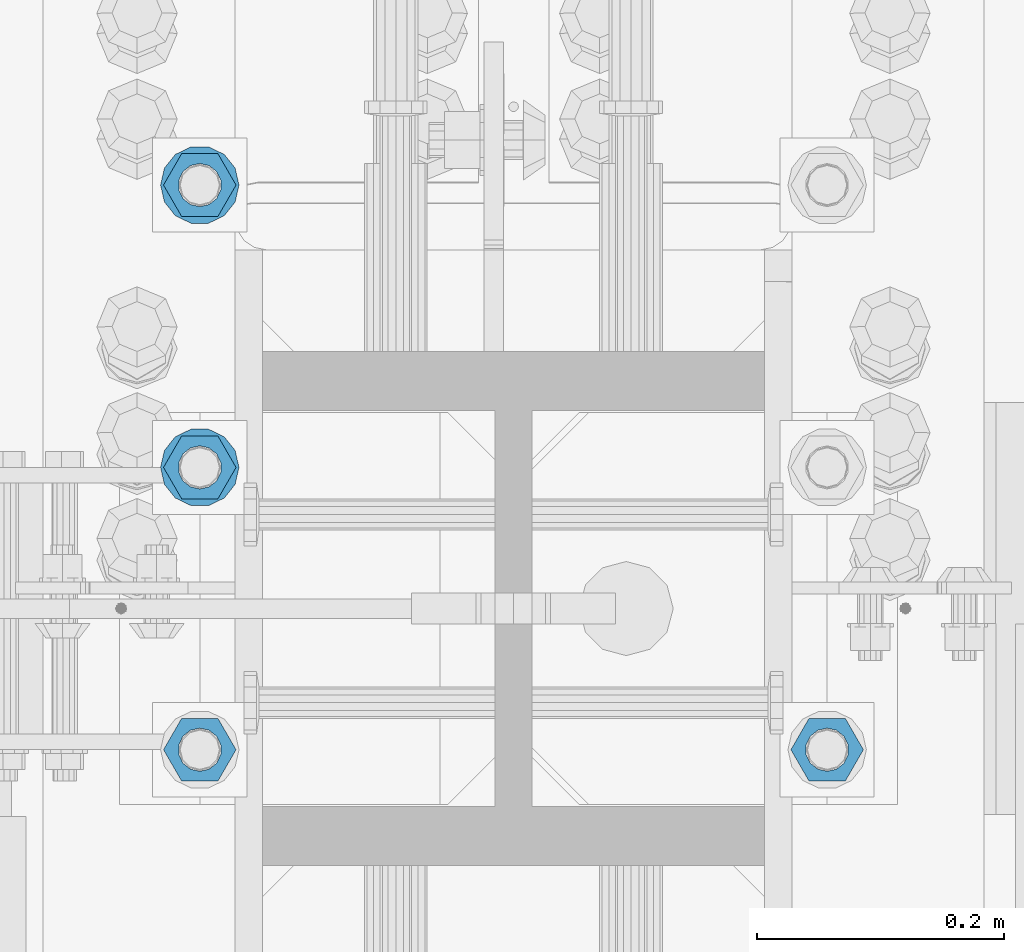
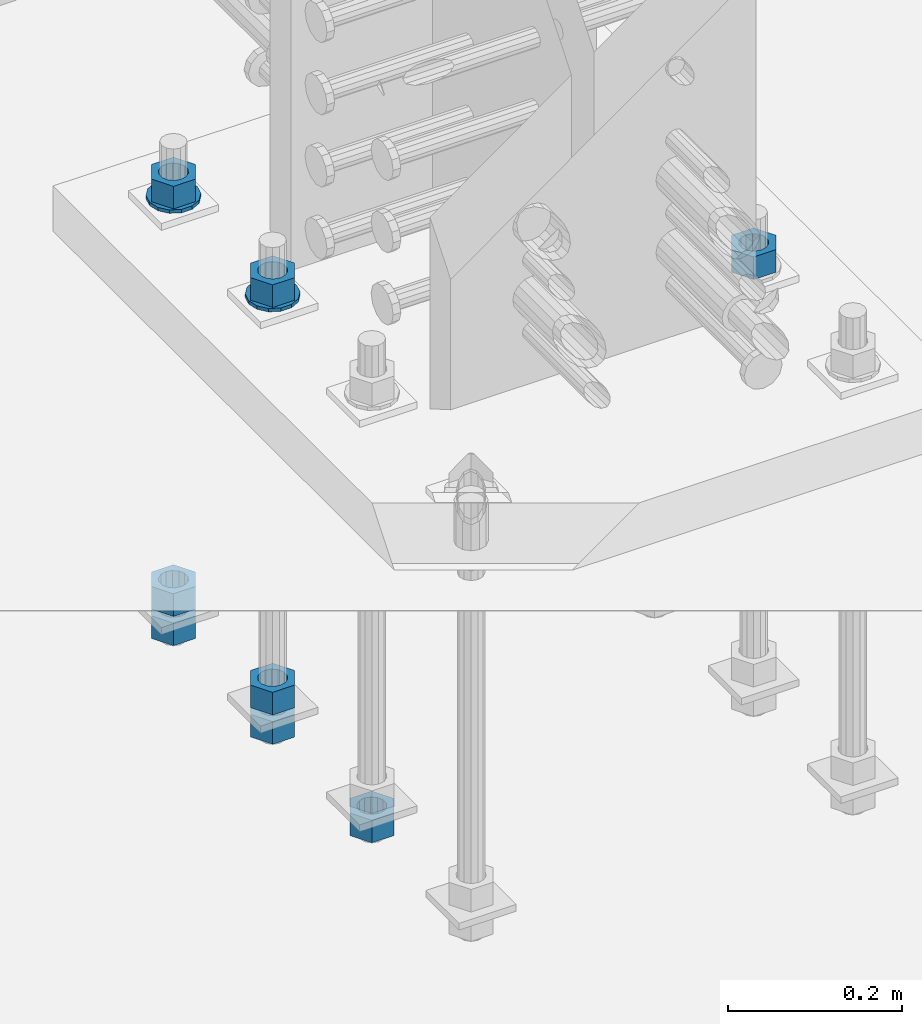
# One storey, part 1008 of 1763: 10 columns, 1 element without a shape of its own.
"""IFC2X3 building model written with IfcOpenShell, lengths in millimetres."""

from ifc_helpers import new_model, si_unit, frame, origin_with_axes, place, context, subcontext, project, spatial, faceted_brep, material, type_object, element, aggregate, save


model = new_model("IFC2X3")

# Units and contexts
model_context = context("Model", 3, precision=1e-05, world=origin_with_axes())
body_context = subcontext(model_context, "Body", "Model", "MODEL_VIEW")
ifc_project = project(units=[si_unit("LENGTHUNIT", "METRE", prefix="MILLI"), si_unit("AREAUNIT", "SQUARE_METRE"), si_unit("VOLUMEUNIT", "CUBIC_METRE"), si_unit("MASSUNIT", "GRAM", prefix="KILO"), si_unit("TIMEUNIT", "SECOND"), si_unit("PLANEANGLEUNIT", "RADIAN"), si_unit("SOLIDANGLEUNIT", "STERADIAN"), si_unit("THERMODYNAMICTEMPERATUREUNIT", "DEGREE_CELSIUS"), si_unit("LUMINOUSINTENSITYUNIT", "LUMEN")], contexts=[model_context])

# Site, building, storey
site_placement = place(None, origin_with_axes())
site = spatial("IfcSite", under=ifc_project, at=site_placement, CompositionType="ELEMENT")
building_placement = place(site_placement, origin_with_axes())
building = spatial("IfcBuilding", under=site, at=building_placement, Name="Undefined", CompositionType="ELEMENT")
storey_placement = place(building_placement, origin_with_axes())
storey = spatial("IfcBuildingStorey", under=building, at=storey_placement, Name="Undefined", CompositionType="ELEMENT", Elevation=0.0)

# Assembly, columns
assembly_placement = place(storey_placement, origin_with_axes())
assembly = element("IfcElementAssembly", 1, at=assembly_placement, inside=storey, Name="TEMPLATE", AssemblyPlace="NOTDEFINED", PredefinedType="RIGID_FRAME")
ifc_material_1 = material(Name="STEEL/A563")
column_type_1 = type_object("IfcColumnType", Name="1-1/4_HEAVY_HEX_NUT", PredefinedType="NOTDEFINED")
column_1_placement = place(assembly_placement, frame((-24281.8372736984, -13830.3000000001, 3343.275), z_axis=(0.0, -1.0, 0.0), x_axis=(0.0, 0.0, -1.0)))
column_1 = element("IfcColumn", 2, at=column_1_placement, type_object=column_type_1, material=ifc_material_1, Name="NUT", ObjectType="1-1/4_HEAVY_HEX_NUT", context=body_context, shape_type="Brep", body=[
    faceted_brep([(0.0, -29.3700008392334, 0.0), (0.0, -14.6800003051758, -25.4300003051758), (31.75, -14.6800003051758, -25.4300003051758), (31.75, -29.3700008392334, 0.0), (0.0, 14.6800003051758, -25.4300003051758), (31.75, 14.6800003051758, -25.4300003051758), (0.0, 29.3700008392334, 0.0), (31.75, 29.3700008392334, 0.0), (0.0, 14.6800003051758, 25.4300003051758), (31.75, 14.6800003051758, 25.4300003051758), (0.0, -14.6800003051758, 25.4300003051758), (31.75, -14.6800003051758, 25.4300003051758), (0.0, 0.0, 17.4599990844727), (0.0, 7.57560968776022, 15.730915608714), (31.75, 7.57560968775942, 15.7309156087145), (31.75, 0.0, 17.4599990844727), (0.0, 13.6507769681037, 10.8861313696252), (31.75, 13.6507769681048, 10.8861313696314), (0.0, 17.0222404541215, 3.88521530314756), (31.75, 17.02224045412, 3.88521530315316), (0.0, 17.0222404541215, -3.88521530314756), (31.75, 17.02224045412, -3.88521530315332), (0.0, 13.6507769681037, -10.8861313696252), (31.75, 13.6507769681048, -10.8861313696316), (0.0, 7.57560968776022, -15.730915608714), (31.75, 7.57560968775942, -15.7309156087146), (0.0, 0.0, -17.4599990844727), (31.75, 0.0, -17.4599990844727), (0.0, -7.57560968776022, -15.730915608714), (31.75, -7.57560968775942, -15.7309156087145), (0.0, -13.6507769681037, -10.8861313696252), (31.75, -13.6507769681048, -10.8861313696314), (0.0, -17.0222404541215, -3.88521530314756), (31.75, -17.02224045412, -3.88521530315316), (0.0, -17.0222404541215, 3.88521530314756), (31.75, -17.02224045412, 3.88521530315332), (0.0, -13.6507769681037, 10.8861313696252), (31.75, -13.6507769681048, 10.8861313696316), (0.0, -7.57560968776022, 15.730915608714), (31.75, -7.57560968775942, 15.7309156087146)], [[[0, 1, 2, 3]], [[1, 4, 5, 2]], [[4, 6, 7, 5]], [[6, 8, 9, 7]], [[8, 10, 11, 9]], [[10, 0, 3, 11]], [[12, 13, 14, 15]], [[13, 16, 17, 14]], [[16, 18, 19, 17]], [[18, 20, 21, 19]], [[20, 22, 23, 21]], [[22, 24, 25, 23]], [[24, 26, 27, 25]], [[26, 28, 29, 27]], [[28, 30, 31, 29]], [[30, 32, 33, 31]], [[32, 34, 35, 33]], [[34, 36, 37, 35]], [[36, 38, 39, 37]], [[38, 12, 15, 39]], [[5, 7, 9, 11, 3, 2], [17, 19, 21, 23, 25, 27, 29, 31, 33, 35, 37, 39, 15, 14]], [[10, 8, 6, 4, 1, 0], [38, 36, 34, 32, 30, 28, 26, 24, 22, 20, 18, 16, 13, 12]]]),
])
column_2_placement = place(assembly_placement, frame((-23773.8372736984, -13830.3000000001, 3957.6375), z_axis=(0.0, 1.0, 0.0), x_axis=(0.0, 0.0, -1.0)))
column_2 = element("IfcColumn", 3, at=column_2_placement, type_object=column_type_1, material=ifc_material_1, Name="NUT", ObjectType="1-1/4_HEAVY_HEX_NUT", context=body_context, shape_type="Brep", body=[
    faceted_brep([(0.0, -29.3700008392334, 0.0), (0.0, -14.6800003051758, -25.4300003051758), (31.75, -14.6800003051758, -25.4300003051758), (31.75, -29.3700008392334, 0.0), (0.0, 14.6800003051758, -25.4300003051758), (31.75, 14.6800003051758, -25.4300003051758), (0.0, 29.3700008392334, 0.0), (31.75, 29.3700008392334, 0.0), (0.0, 14.6800003051758, 25.4300003051758), (31.75, 14.6800003051758, 25.4300003051758), (0.0, -14.6800003051758, 25.4300003051758), (31.75, -14.6800003051758, 25.4300003051758), (0.0, 0.0, 17.4599990844727), (0.0, 7.57560968776022, 15.730915608714), (31.75, 7.57560968775942, 15.7309156087145), (31.75, 0.0, 17.4599990844727), (0.0, 13.6507769681037, 10.8861313696252), (31.75, 13.6507769681048, 10.8861313696314), (0.0, 17.0222404541215, 3.88521530314756), (31.75, 17.02224045412, 3.88521530315316), (0.0, 17.0222404541215, -3.88521530314756), (31.75, 17.02224045412, -3.88521530315332), (0.0, 13.6507769681037, -10.8861313696252), (31.75, 13.6507769681048, -10.8861313696316), (0.0, 7.57560968776022, -15.730915608714), (31.75, 7.57560968775942, -15.7309156087146), (0.0, 0.0, -17.4599990844727), (31.75, 0.0, -17.4599990844727), (0.0, -7.57560968776022, -15.730915608714), (31.75, -7.57560968775942, -15.7309156087145), (0.0, -13.6507769681037, -10.8861313696252), (31.75, -13.6507769681048, -10.8861313696314), (0.0, -17.0222404541215, -3.88521530314756), (31.75, -17.02224045412, -3.88521530315316), (0.0, -17.0222404541215, 3.88521530314756), (31.75, -17.02224045412, 3.88521530315332), (0.0, -13.6507769681037, 10.8861313696252), (31.75, -13.6507769681048, 10.8861313696316), (0.0, -7.57560968776022, 15.730915608714), (31.75, -7.57560968775942, 15.7309156087146)], [[[0, 1, 2, 3]], [[1, 4, 5, 2]], [[4, 6, 7, 5]], [[6, 8, 9, 7]], [[8, 10, 11, 9]], [[10, 0, 3, 11]], [[12, 13, 14, 15]], [[13, 16, 17, 14]], [[16, 18, 19, 17]], [[18, 20, 21, 19]], [[20, 22, 23, 21]], [[22, 24, 25, 23]], [[24, 26, 27, 25]], [[26, 28, 29, 27]], [[28, 30, 31, 29]], [[30, 32, 33, 31]], [[32, 34, 35, 33]], [[34, 36, 37, 35]], [[36, 38, 39, 37]], [[38, 12, 15, 39]], [[5, 7, 9, 11, 3, 2], [17, 19, 21, 23, 25, 27, 29, 31, 33, 35, 37, 39, 15, 14]], [[10, 8, 6, 4, 1, 0], [38, 36, 34, 32, 30, 28, 26, 24, 22, 20, 18, 16, 13, 12]]]),
])
column_3_placement = place(assembly_placement, frame((-24281.8372736984, -13601.7000000001, 3957.6375), z_axis=(0.0, -1.0, 0.0), x_axis=(0.0, 0.0, -1.0)))
column_3 = element("IfcColumn", 4, at=column_3_placement, type_object=column_type_1, material=ifc_material_1, Name="NUT", ObjectType="1-1/4_HEAVY_HEX_NUT", context=body_context, shape_type="Brep", body=[
    faceted_brep([(0.0, -29.3700008392334, 0.0), (0.0, -14.6800003051758, -25.4300003051758), (31.75, -14.6800003051758, -25.4300003051758), (31.75, -29.3700008392334, 0.0), (0.0, 14.6800003051758, -25.4300003051758), (31.75, 14.6800003051758, -25.4300003051758), (0.0, 29.3700008392334, 0.0), (31.75, 29.3700008392334, 0.0), (0.0, 14.6800003051758, 25.4300003051758), (31.75, 14.6800003051758, 25.4300003051758), (0.0, -14.6800003051758, 25.4300003051758), (31.75, -14.6800003051758, 25.4300003051758), (0.0, 0.0, 17.4599990844727), (0.0, 7.57560968776022, 15.730915608714), (31.75, 7.57560968775942, 15.7309156087145), (31.75, 0.0, 17.4599990844727), (0.0, 13.6507769681037, 10.8861313696252), (31.75, 13.6507769681048, 10.8861313696314), (0.0, 17.0222404541215, 3.88521530314756), (31.75, 17.02224045412, 3.88521530315316), (0.0, 17.0222404541215, -3.88521530314756), (31.75, 17.02224045412, -3.88521530315332), (0.0, 13.6507769681037, -10.8861313696252), (31.75, 13.6507769681048, -10.8861313696316), (0.0, 7.57560968776022, -15.730915608714), (31.75, 7.57560968775942, -15.7309156087146), (0.0, 0.0, -17.4599990844727), (31.75, 0.0, -17.4599990844727), (0.0, -7.57560968776022, -15.730915608714), (31.75, -7.57560968775942, -15.7309156087145), (0.0, -13.6507769681037, -10.8861313696252), (31.75, -13.6507769681048, -10.8861313696314), (0.0, -17.0222404541215, -3.88521530314756), (31.75, -17.02224045412, -3.88521530315316), (0.0, -17.0222404541215, 3.88521530314756), (31.75, -17.02224045412, 3.88521530315332), (0.0, -13.6507769681037, 10.8861313696252), (31.75, -13.6507769681048, 10.8861313696316), (0.0, -7.57560968776022, 15.730915608714), (31.75, -7.57560968775942, 15.7309156087146)], [[[0, 1, 2, 3]], [[1, 4, 5, 2]], [[4, 6, 7, 5]], [[6, 8, 9, 7]], [[8, 10, 11, 9]], [[10, 0, 3, 11]], [[12, 13, 14, 15]], [[13, 16, 17, 14]], [[16, 18, 19, 17]], [[18, 20, 21, 19]], [[20, 22, 23, 21]], [[22, 24, 25, 23]], [[24, 26, 27, 25]], [[26, 28, 29, 27]], [[28, 30, 31, 29]], [[30, 32, 33, 31]], [[32, 34, 35, 33]], [[34, 36, 37, 35]], [[36, 38, 39, 37]], [[38, 12, 15, 39]], [[5, 7, 9, 11, 3, 2], [17, 19, 21, 23, 25, 27, 29, 31, 33, 35, 37, 39, 15, 14]], [[10, 8, 6, 4, 1, 0], [38, 36, 34, 32, 30, 28, 26, 24, 22, 20, 18, 16, 13, 12]]]),
])
column_4_placement = place(assembly_placement, frame((-24281.8372736984, -13601.7000000001, 3384.55), z_axis=(0.0, -1.0, 0.0), x_axis=(0.0, 0.0, -1.0)))
column_4 = element("IfcColumn", 5, at=column_4_placement, type_object=column_type_1, material=ifc_material_1, Name="NUT", ObjectType="1-1/4_HEAVY_HEX_NUT", context=body_context, shape_type="Brep", body=[
    faceted_brep([(0.0, -29.3700008392334, 0.0), (0.0, -14.6800003051758, -25.4300003051758), (31.75, -14.6800003051758, -25.4300003051758), (31.75, -29.3700008392334, 0.0), (0.0, 14.6800003051758, -25.4300003051758), (31.75, 14.6800003051758, -25.4300003051758), (0.0, 29.3700008392334, 0.0), (31.75, 29.3700008392334, 0.0), (0.0, 14.6800003051758, 25.4300003051758), (31.75, 14.6800003051758, 25.4300003051758), (0.0, -14.6800003051758, 25.4300003051758), (31.75, -14.6800003051758, 25.4300003051758), (0.0, 0.0, 17.4599990844727), (0.0, 7.57560968776022, 15.730915608714), (31.75, 7.57560968775942, 15.7309156087145), (31.75, 0.0, 17.4599990844727), (0.0, 13.6507769681037, 10.8861313696252), (31.75, 13.6507769681048, 10.8861313696314), (0.0, 17.0222404541215, 3.88521530314756), (31.75, 17.02224045412, 3.88521530315316), (0.0, 17.0222404541215, -3.88521530314756), (31.75, 17.02224045412, -3.88521530315332), (0.0, 13.6507769681037, -10.8861313696252), (31.75, 13.6507769681048, -10.8861313696316), (0.0, 7.57560968776022, -15.730915608714), (31.75, 7.57560968775942, -15.7309156087146), (0.0, 0.0, -17.4599990844727), (31.75, 0.0, -17.4599990844727), (0.0, -7.57560968776022, -15.730915608714), (31.75, -7.57560968775942, -15.7309156087145), (0.0, -13.6507769681037, -10.8861313696252), (31.75, -13.6507769681048, -10.8861313696314), (0.0, -17.0222404541215, -3.88521530314756), (31.75, -17.02224045412, -3.88521530315316), (0.0, -17.0222404541215, 3.88521530314756), (31.75, -17.02224045412, 3.88521530315332), (0.0, -13.6507769681037, 10.8861313696252), (31.75, -13.6507769681048, 10.8861313696316), (0.0, -7.57560968776022, 15.730915608714), (31.75, -7.57560968775942, 15.7309156087146)], [[[0, 1, 2, 3]], [[1, 4, 5, 2]], [[4, 6, 7, 5]], [[6, 8, 9, 7]], [[8, 10, 11, 9]], [[10, 0, 3, 11]], [[12, 13, 14, 15]], [[13, 16, 17, 14]], [[16, 18, 19, 17]], [[18, 20, 21, 19]], [[20, 22, 23, 21]], [[22, 24, 25, 23]], [[24, 26, 27, 25]], [[26, 28, 29, 27]], [[28, 30, 31, 29]], [[30, 32, 33, 31]], [[32, 34, 35, 33]], [[34, 36, 37, 35]], [[36, 38, 39, 37]], [[38, 12, 15, 39]], [[5, 7, 9, 11, 3, 2], [17, 19, 21, 23, 25, 27, 29, 31, 33, 35, 37, 39, 15, 14]], [[10, 8, 6, 4, 1, 0], [38, 36, 34, 32, 30, 28, 26, 24, 22, 20, 18, 16, 13, 12]]]),
])
column_5_placement = place(assembly_placement, frame((-24281.8372736984, -13601.7000000001, 3343.275), z_axis=(0.0, -1.0, 0.0), x_axis=(0.0, 0.0, -1.0)))
column_5 = element("IfcColumn", 6, at=column_5_placement, type_object=column_type_1, material=ifc_material_1, Name="NUT", ObjectType="1-1/4_HEAVY_HEX_NUT", context=body_context, shape_type="Brep", body=[
    faceted_brep([(0.0, -29.3700008392334, 0.0), (0.0, -14.6800003051758, -25.4300003051758), (31.75, -14.6800003051758, -25.4300003051758), (31.75, -29.3700008392334, 0.0), (0.0, 14.6800003051758, -25.4300003051758), (31.75, 14.6800003051758, -25.4300003051758), (0.0, 29.3700008392334, 0.0), (31.75, 29.3700008392334, 0.0), (0.0, 14.6800003051758, 25.4300003051758), (31.75, 14.6800003051758, 25.4300003051758), (0.0, -14.6800003051758, 25.4300003051758), (31.75, -14.6800003051758, 25.4300003051758), (0.0, 0.0, 17.4599990844727), (0.0, 7.57560968776022, 15.730915608714), (31.75, 7.57560968775942, 15.7309156087145), (31.75, 0.0, 17.4599990844727), (0.0, 13.6507769681037, 10.8861313696252), (31.75, 13.6507769681048, 10.8861313696314), (0.0, 17.0222404541215, 3.88521530314756), (31.75, 17.02224045412, 3.88521530315316), (0.0, 17.0222404541215, -3.88521530314756), (31.75, 17.02224045412, -3.88521530315332), (0.0, 13.6507769681037, -10.8861313696252), (31.75, 13.6507769681048, -10.8861313696316), (0.0, 7.57560968776022, -15.730915608714), (31.75, 7.57560968775942, -15.7309156087146), (0.0, 0.0, -17.4599990844727), (31.75, 0.0, -17.4599990844727), (0.0, -7.57560968776022, -15.730915608714), (31.75, -7.57560968775942, -15.7309156087145), (0.0, -13.6507769681037, -10.8861313696252), (31.75, -13.6507769681048, -10.8861313696314), (0.0, -17.0222404541215, -3.88521530314756), (31.75, -17.02224045412, -3.88521530315316), (0.0, -17.0222404541215, 3.88521530314756), (31.75, -17.02224045412, 3.88521530315332), (0.0, -13.6507769681037, 10.8861313696252), (31.75, -13.6507769681048, 10.8861313696316), (0.0, -7.57560968776022, 15.730915608714), (31.75, -7.57560968775942, 15.7309156087146)], [[[0, 1, 2, 3]], [[1, 4, 5, 2]], [[4, 6, 7, 5]], [[6, 8, 9, 7]], [[8, 10, 11, 9]], [[10, 0, 3, 11]], [[12, 13, 14, 15]], [[13, 16, 17, 14]], [[16, 18, 19, 17]], [[18, 20, 21, 19]], [[20, 22, 23, 21]], [[22, 24, 25, 23]], [[24, 26, 27, 25]], [[26, 28, 29, 27]], [[28, 30, 31, 29]], [[30, 32, 33, 31]], [[32, 34, 35, 33]], [[34, 36, 37, 35]], [[36, 38, 39, 37]], [[38, 12, 15, 39]], [[5, 7, 9, 11, 3, 2], [17, 19, 21, 23, 25, 27, 29, 31, 33, 35, 37, 39, 15, 14]], [[10, 8, 6, 4, 1, 0], [38, 36, 34, 32, 30, 28, 26, 24, 22, 20, 18, 16, 13, 12]]]),
])
column_6_placement = place(assembly_placement, frame((-24281.8372736984, -13373.1000000001, 3957.6375), z_axis=(0.0, -1.0, 0.0), x_axis=(0.0, 0.0, -1.0)))
column_6 = element("IfcColumn", 7, at=column_6_placement, type_object=column_type_1, material=ifc_material_1, Name="NUT", ObjectType="1-1/4_HEAVY_HEX_NUT", context=body_context, shape_type="Brep", body=[
    faceted_brep([(0.0, -29.3700008392334, 0.0), (0.0, -14.6800003051758, -25.4300003051758), (31.75, -14.6800003051758, -25.4300003051758), (31.75, -29.3700008392334, 0.0), (0.0, 14.6800003051758, -25.4300003051758), (31.75, 14.6800003051758, -25.4300003051758), (0.0, 29.3700008392334, 0.0), (31.75, 29.3700008392334, 0.0), (0.0, 14.6800003051758, 25.4300003051758), (31.75, 14.6800003051758, 25.4300003051758), (0.0, -14.6800003051758, 25.4300003051758), (31.75, -14.6800003051758, 25.4300003051758), (0.0, 0.0, 17.4599990844727), (0.0, 7.57560968776022, 15.730915608714), (31.75, 7.57560968775942, 15.7309156087145), (31.75, 0.0, 17.4599990844727), (0.0, 13.6507769681037, 10.8861313696252), (31.75, 13.6507769681048, 10.8861313696314), (0.0, 17.0222404541215, 3.88521530314756), (31.75, 17.02224045412, 3.88521530315316), (0.0, 17.0222404541215, -3.88521530314756), (31.75, 17.02224045412, -3.88521530315332), (0.0, 13.6507769681037, -10.8861313696252), (31.75, 13.6507769681048, -10.8861313696316), (0.0, 7.57560968776022, -15.730915608714), (31.75, 7.57560968775942, -15.7309156087146), (0.0, 0.0, -17.4599990844727), (31.75, 0.0, -17.4599990844727), (0.0, -7.57560968776022, -15.730915608714), (31.75, -7.57560968775942, -15.7309156087145), (0.0, -13.6507769681037, -10.8861313696252), (31.75, -13.6507769681048, -10.8861313696314), (0.0, -17.0222404541215, -3.88521530314756), (31.75, -17.02224045412, -3.88521530315316), (0.0, -17.0222404541215, 3.88521530314756), (31.75, -17.02224045412, 3.88521530315332), (0.0, -13.6507769681037, 10.8861313696252), (31.75, -13.6507769681048, 10.8861313696316), (0.0, -7.57560968776022, 15.730915608714), (31.75, -7.57560968775942, 15.7309156087146)], [[[0, 1, 2, 3]], [[1, 4, 5, 2]], [[4, 6, 7, 5]], [[6, 8, 9, 7]], [[8, 10, 11, 9]], [[10, 0, 3, 11]], [[12, 13, 14, 15]], [[13, 16, 17, 14]], [[16, 18, 19, 17]], [[18, 20, 21, 19]], [[20, 22, 23, 21]], [[22, 24, 25, 23]], [[24, 26, 27, 25]], [[26, 28, 29, 27]], [[28, 30, 31, 29]], [[30, 32, 33, 31]], [[32, 34, 35, 33]], [[34, 36, 37, 35]], [[36, 38, 39, 37]], [[38, 12, 15, 39]], [[5, 7, 9, 11, 3, 2], [17, 19, 21, 23, 25, 27, 29, 31, 33, 35, 37, 39, 15, 14]], [[10, 8, 6, 4, 1, 0], [38, 36, 34, 32, 30, 28, 26, 24, 22, 20, 18, 16, 13, 12]]]),
])
column_7_placement = place(assembly_placement, frame((-24281.8372736984, -13373.1000000001, 3384.55), z_axis=(0.0, -1.0, 0.0), x_axis=(0.0, 0.0, -1.0)))
column_7 = element("IfcColumn", 8, at=column_7_placement, type_object=column_type_1, material=ifc_material_1, Name="NUT", ObjectType="1-1/4_HEAVY_HEX_NUT", context=body_context, shape_type="Brep", body=[
    faceted_brep([(0.0, -29.3700008392334, 0.0), (0.0, -14.6800003051758, -25.4300003051758), (31.75, -14.6800003051758, -25.4300003051758), (31.75, -29.3700008392334, 0.0), (0.0, 14.6800003051758, -25.4300003051758), (31.75, 14.6800003051758, -25.4300003051758), (0.0, 29.3700008392334, 0.0), (31.75, 29.3700008392334, 0.0), (0.0, 14.6800003051758, 25.4300003051758), (31.75, 14.6800003051758, 25.4300003051758), (0.0, -14.6800003051758, 25.4300003051758), (31.75, -14.6800003051758, 25.4300003051758), (0.0, 0.0, 17.4599990844727), (0.0, 7.57560968776022, 15.730915608714), (31.75, 7.57560968775942, 15.7309156087145), (31.75, 0.0, 17.4599990844727), (0.0, 13.6507769681037, 10.8861313696252), (31.75, 13.6507769681048, 10.8861313696314), (0.0, 17.0222404541215, 3.88521530314756), (31.75, 17.02224045412, 3.88521530315316), (0.0, 17.0222404541215, -3.88521530314756), (31.75, 17.02224045412, -3.88521530315332), (0.0, 13.6507769681037, -10.8861313696252), (31.75, 13.6507769681048, -10.8861313696316), (0.0, 7.57560968776022, -15.730915608714), (31.75, 7.57560968775942, -15.7309156087146), (0.0, 0.0, -17.4599990844727), (31.75, 0.0, -17.4599990844727), (0.0, -7.57560968776022, -15.730915608714), (31.75, -7.57560968775942, -15.7309156087145), (0.0, -13.6507769681037, -10.8861313696252), (31.75, -13.6507769681048, -10.8861313696314), (0.0, -17.0222404541215, -3.88521530314756), (31.75, -17.02224045412, -3.88521530315316), (0.0, -17.0222404541215, 3.88521530314756), (31.75, -17.02224045412, 3.88521530315332), (0.0, -13.6507769681037, 10.8861313696252), (31.75, -13.6507769681048, 10.8861313696316), (0.0, -7.57560968776022, 15.730915608714), (31.75, -7.57560968775942, 15.7309156087146)], [[[0, 1, 2, 3]], [[1, 4, 5, 2]], [[4, 6, 7, 5]], [[6, 8, 9, 7]], [[8, 10, 11, 9]], [[10, 0, 3, 11]], [[12, 13, 14, 15]], [[13, 16, 17, 14]], [[16, 18, 19, 17]], [[18, 20, 21, 19]], [[20, 22, 23, 21]], [[22, 24, 25, 23]], [[24, 26, 27, 25]], [[26, 28, 29, 27]], [[28, 30, 31, 29]], [[30, 32, 33, 31]], [[32, 34, 35, 33]], [[34, 36, 37, 35]], [[36, 38, 39, 37]], [[38, 12, 15, 39]], [[5, 7, 9, 11, 3, 2], [17, 19, 21, 23, 25, 27, 29, 31, 33, 35, 37, 39, 15, 14]], [[10, 8, 6, 4, 1, 0], [38, 36, 34, 32, 30, 28, 26, 24, 22, 20, 18, 16, 13, 12]]]),
])
column_8_placement = place(assembly_placement, frame((-24281.8372736984, -13373.1000000001, 3343.275), z_axis=(0.0, -1.0, 0.0), x_axis=(0.0, 0.0, -1.0)))
column_8 = element("IfcColumn", 9, at=column_8_placement, type_object=column_type_1, material=ifc_material_1, Name="NUT", ObjectType="1-1/4_HEAVY_HEX_NUT", context=body_context, shape_type="Brep", body=[
    faceted_brep([(0.0, -29.3700008392334, 0.0), (0.0, -14.6800003051758, -25.4300003051758), (31.75, -14.6800003051758, -25.4300003051758), (31.75, -29.3700008392334, 0.0), (0.0, 14.6800003051758, -25.4300003051758), (31.75, 14.6800003051758, -25.4300003051758), (0.0, 29.3700008392334, 0.0), (31.75, 29.3700008392334, 0.0), (0.0, 14.6800003051758, 25.4300003051758), (31.75, 14.6800003051758, 25.4300003051758), (0.0, -14.6800003051758, 25.4300003051758), (31.75, -14.6800003051758, 25.4300003051758), (0.0, 0.0, 17.4599990844727), (0.0, 7.57560968776022, 15.730915608714), (31.75, 7.57560968775942, 15.7309156087145), (31.75, 0.0, 17.4599990844727), (0.0, 13.6507769681037, 10.8861313696252), (31.75, 13.6507769681048, 10.8861313696314), (0.0, 17.0222404541215, 3.88521530314756), (31.75, 17.02224045412, 3.88521530315316), (0.0, 17.0222404541215, -3.88521530314756), (31.75, 17.02224045412, -3.88521530315332), (0.0, 13.6507769681037, -10.8861313696252), (31.75, 13.6507769681048, -10.8861313696316), (0.0, 7.57560968776022, -15.730915608714), (31.75, 7.57560968775942, -15.7309156087146), (0.0, 0.0, -17.4599990844727), (31.75, 0.0, -17.4599990844727), (0.0, -7.57560968776022, -15.730915608714), (31.75, -7.57560968775942, -15.7309156087145), (0.0, -13.6507769681037, -10.8861313696252), (31.75, -13.6507769681048, -10.8861313696314), (0.0, -17.0222404541215, -3.88521530314756), (31.75, -17.02224045412, -3.88521530315316), (0.0, -17.0222404541215, 3.88521530314756), (31.75, -17.02224045412, 3.88521530315332), (0.0, -13.6507769681037, 10.8861313696252), (31.75, -13.6507769681048, 10.8861313696316), (0.0, -7.57560968776022, 15.730915608714), (31.75, -7.57560968775942, 15.7309156087146)], [[[0, 1, 2, 3]], [[1, 4, 5, 2]], [[4, 6, 7, 5]], [[6, 8, 9, 7]], [[8, 10, 11, 9]], [[10, 0, 3, 11]], [[12, 13, 14, 15]], [[13, 16, 17, 14]], [[16, 18, 19, 17]], [[18, 20, 21, 19]], [[20, 22, 23, 21]], [[22, 24, 25, 23]], [[24, 26, 27, 25]], [[26, 28, 29, 27]], [[28, 30, 31, 29]], [[30, 32, 33, 31]], [[32, 34, 35, 33]], [[34, 36, 37, 35]], [[36, 38, 39, 37]], [[38, 12, 15, 39]], [[5, 7, 9, 11, 3, 2], [17, 19, 21, 23, 25, 27, 29, 31, 33, 35, 37, 39, 15, 14]], [[10, 8, 6, 4, 1, 0], [38, 36, 34, 32, 30, 28, 26, 24, 22, 20, 18, 16, 13, 12]]]),
])
ifc_material_2 = material(Name="STEEL/F436")
column_type_2 = type_object("IfcColumnType", Name="1-1/4_WASHER", PredefinedType="NOTDEFINED")
column_9_placement = place(assembly_placement, frame((-24281.8372736984, -13601.7000000001, 3925.8875), z_axis=(0.0, -1.0, 0.0), x_axis=(0.0, 0.0, -1.0)))
column_9 = element("IfcColumn", 10, at=column_9_placement, type_object=column_type_2, material=ifc_material_2, Name="WASHER", ObjectType="1-1/4_WASHER", context=body_context, shape_type="Brep", body=[
    faceted_brep([(-4.54747350886464e-13, -31.7499999999964, 0.0), (0.0, -28.6057615559002, -13.7758087169827), (4.76249999999982, -28.6057615559002, -13.7758087169827), (4.76249999999982, -31.75, 0.0), (0.0, -19.795801209013, -24.8231495683602), (4.76249999999982, -19.795801209013, -24.8231495683602), (0.0, -7.06503965311276, -30.9539612117732), (4.76249999999982, -7.06503965311276, -30.9539612117732), (0.0, 7.06503965311276, -30.9539612117732), (4.76249999999982, 7.06503965311276, -30.9539612117732), (0.0, 19.7958012090166, -24.8231495683602), (4.76249999999982, 19.7958012090166, -24.8231495683602), (0.0, 28.6057615559039, -13.7758087169827), (4.76249999999982, 28.6057615559039, -13.7758087169827), (-5.91171556152403e-12, 31.7499999999891, 0.0), (4.76249999999982, 31.75, 0.0), (0.0, 28.6057615559002, 13.7758087169827), (4.76249999999982, 28.6057615559002, 13.7758087169827), (0.0, 19.795801209013, 24.8231495683602), (4.76249999999982, 19.795801209013, 24.8231495683602), (0.0, 7.06503965311276, 30.9539612117731), (4.76249999999982, 7.06503965311276, 30.9539612117731), (0.0, -7.06503965311276, 30.9539612117731), (4.76249999999982, -7.06503965311276, 30.9539612117731), (0.0, -19.7958012090166, 24.8231495683602), (4.76249999999982, -19.7958012090166, 24.8231495683602), (0.0, -28.6057615559039, 13.7758087169827), (4.76249999999982, -28.6057615559039, 13.7758087169827), (0.0, 0.0, 17.4599990844727), (0.0, 7.57560968776022, 15.730915608714), (4.76249999999982, 7.57560968775942, 15.7309156087145), (4.76249999999982, 0.0, 17.4599990844727), (0.0, 13.6507769681037, 10.8861313696252), (4.76249999999982, 13.6507769681048, 10.8861313696314), (0.0, 17.0222404541215, 3.88521530314756), (4.76249999999982, 17.02224045412, 3.88521530315316), (0.0, 17.0222404541215, -3.88521530314756), (4.76249999999982, 17.02224045412, -3.88521530315332), (0.0, 13.6507769681037, -10.8861313696252), (4.76249999999982, 13.6507769681048, -10.8861313696316), (0.0, 7.57560968776022, -15.730915608714), (4.76249999999982, 7.57560968775942, -15.7309156087146), (0.0, 0.0, -17.4599990844727), (4.76249999999982, 0.0, -17.4599990844727), (0.0, -7.57560968776022, -15.730915608714), (4.76249999999982, -7.57560968775942, -15.7309156087145), (0.0, -13.6507769681037, -10.8861313696252), (4.76249999999982, -13.6507769681048, -10.8861313696314), (0.0, -17.0222404541215, -3.88521530314756), (4.76249999999982, -17.02224045412, -3.88521530315316), (0.0, -17.0222404541215, 3.88521530314756), (4.76249999999982, -17.02224045412, 3.88521530315332), (0.0, -13.6507769681037, 10.8861313696252), (4.76249999999982, -13.6507769681048, 10.8861313696316), (0.0, -7.57560968776022, 15.730915608714), (4.76249999999982, -7.57560968775942, 15.7309156087146)], [[[0, 1, 2, 3]], [[1, 4, 5, 2]], [[4, 6, 7, 5]], [[6, 8, 9, 7]], [[8, 10, 11, 9]], [[10, 12, 13, 11]], [[12, 14, 15, 13]], [[14, 16, 17, 15]], [[16, 18, 19, 17]], [[18, 20, 21, 19]], [[20, 22, 23, 21]], [[22, 24, 25, 23]], [[24, 26, 27, 25]], [[26, 0, 3, 27]], [[28, 29, 30, 31]], [[29, 32, 33, 30]], [[32, 34, 35, 33]], [[34, 36, 37, 35]], [[36, 38, 39, 37]], [[38, 40, 41, 39]], [[40, 42, 43, 41]], [[42, 44, 45, 43]], [[44, 46, 47, 45]], [[46, 48, 49, 47]], [[48, 50, 51, 49]], [[50, 52, 53, 51]], [[52, 54, 55, 53]], [[54, 28, 31, 55]], [[5, 7, 9, 11, 13, 15, 17, 19, 21, 23, 25, 27, 3, 2], [33, 35, 37, 39, 41, 43, 45, 47, 49, 51, 53, 55, 31, 30]], [[26, 24, 22, 20, 18, 16, 14, 12, 10, 8, 6, 4, 1, 0], [54, 52, 50, 48, 46, 44, 42, 40, 38, 36, 34, 32, 29, 28]]]),
])
column_10_placement = place(assembly_placement, frame((-24281.8372736984, -13373.1000000001, 3925.8875), z_axis=(0.0, -1.0, 0.0), x_axis=(0.0, 0.0, -1.0)))
column_10 = element("IfcColumn", 11, at=column_10_placement, type_object=column_type_2, material=ifc_material_2, Name="WASHER", ObjectType="1-1/4_WASHER", context=body_context, shape_type="Brep", body=[
    faceted_brep([(-4.54747350886464e-13, -31.7499999999964, 0.0), (0.0, -28.6057615559002, -13.7758087169827), (4.76249999999982, -28.6057615559002, -13.7758087169827), (4.76249999999982, -31.75, 0.0), (0.0, -19.795801209013, -24.8231495683602), (4.76249999999982, -19.795801209013, -24.8231495683602), (0.0, -7.06503965311276, -30.9539612117732), (4.76249999999982, -7.06503965311276, -30.9539612117732), (0.0, 7.06503965311276, -30.9539612117732), (4.76249999999982, 7.06503965311276, -30.9539612117732), (0.0, 19.7958012090166, -24.8231495683602), (4.76249999999982, 19.7958012090166, -24.8231495683602), (0.0, 28.6057615559039, -13.7758087169827), (4.76249999999982, 28.6057615559039, -13.7758087169827), (-5.91171556152403e-12, 31.7499999999891, 0.0), (4.76249999999982, 31.75, 0.0), (0.0, 28.6057615559002, 13.7758087169827), (4.76249999999982, 28.6057615559002, 13.7758087169827), (0.0, 19.795801209013, 24.8231495683602), (4.76249999999982, 19.795801209013, 24.8231495683602), (0.0, 7.06503965311276, 30.9539612117731), (4.76249999999982, 7.06503965311276, 30.9539612117731), (0.0, -7.06503965311276, 30.9539612117731), (4.76249999999982, -7.06503965311276, 30.9539612117731), (0.0, -19.7958012090166, 24.8231495683602), (4.76249999999982, -19.7958012090166, 24.8231495683602), (0.0, -28.6057615559039, 13.7758087169827), (4.76249999999982, -28.6057615559039, 13.7758087169827), (0.0, 0.0, 17.4599990844727), (0.0, 7.57560968776022, 15.730915608714), (4.76249999999982, 7.57560968775942, 15.7309156087145), (4.76249999999982, 0.0, 17.4599990844727), (0.0, 13.6507769681037, 10.8861313696252), (4.76249999999982, 13.6507769681048, 10.8861313696314), (0.0, 17.0222404541215, 3.88521530314756), (4.76249999999982, 17.02224045412, 3.88521530315316), (0.0, 17.0222404541215, -3.88521530314756), (4.76249999999982, 17.02224045412, -3.88521530315332), (0.0, 13.6507769681037, -10.8861313696252), (4.76249999999982, 13.6507769681048, -10.8861313696316), (0.0, 7.57560968776022, -15.730915608714), (4.76249999999982, 7.57560968775942, -15.7309156087146), (0.0, 0.0, -17.4599990844727), (4.76249999999982, 0.0, -17.4599990844727), (0.0, -7.57560968776022, -15.730915608714), (4.76249999999982, -7.57560968775942, -15.7309156087145), (0.0, -13.6507769681037, -10.8861313696252), (4.76249999999982, -13.6507769681048, -10.8861313696314), (0.0, -17.0222404541215, -3.88521530314756), (4.76249999999982, -17.02224045412, -3.88521530315316), (0.0, -17.0222404541215, 3.88521530314756), (4.76249999999982, -17.02224045412, 3.88521530315332), (0.0, -13.6507769681037, 10.8861313696252), (4.76249999999982, -13.6507769681048, 10.8861313696316), (0.0, -7.57560968776022, 15.730915608714), (4.76249999999982, -7.57560968775942, 15.7309156087146)], [[[0, 1, 2, 3]], [[1, 4, 5, 2]], [[4, 6, 7, 5]], [[6, 8, 9, 7]], [[8, 10, 11, 9]], [[10, 12, 13, 11]], [[12, 14, 15, 13]], [[14, 16, 17, 15]], [[16, 18, 19, 17]], [[18, 20, 21, 19]], [[20, 22, 23, 21]], [[22, 24, 25, 23]], [[24, 26, 27, 25]], [[26, 0, 3, 27]], [[28, 29, 30, 31]], [[29, 32, 33, 30]], [[32, 34, 35, 33]], [[34, 36, 37, 35]], [[36, 38, 39, 37]], [[38, 40, 41, 39]], [[40, 42, 43, 41]], [[42, 44, 45, 43]], [[44, 46, 47, 45]], [[46, 48, 49, 47]], [[48, 50, 51, 49]], [[50, 52, 53, 51]], [[52, 54, 55, 53]], [[54, 28, 31, 55]], [[5, 7, 9, 11, 13, 15, 17, 19, 21, 23, 25, 27, 3, 2], [33, 35, 37, 39, 41, 43, 45, 47, 49, 51, 53, 55, 31, 30]], [[26, 24, 22, 20, 18, 16, 14, 12, 10, 8, 6, 4, 1, 0], [54, 52, 50, 48, 46, 44, 42, 40, 38, 36, 34, 32, 29, 28]]]),
])
aggregate(assembly, [column_1, column_2, column_3, column_9, column_4, column_5, column_6, column_10, column_7, column_8])

save(model, "model.ifc")
